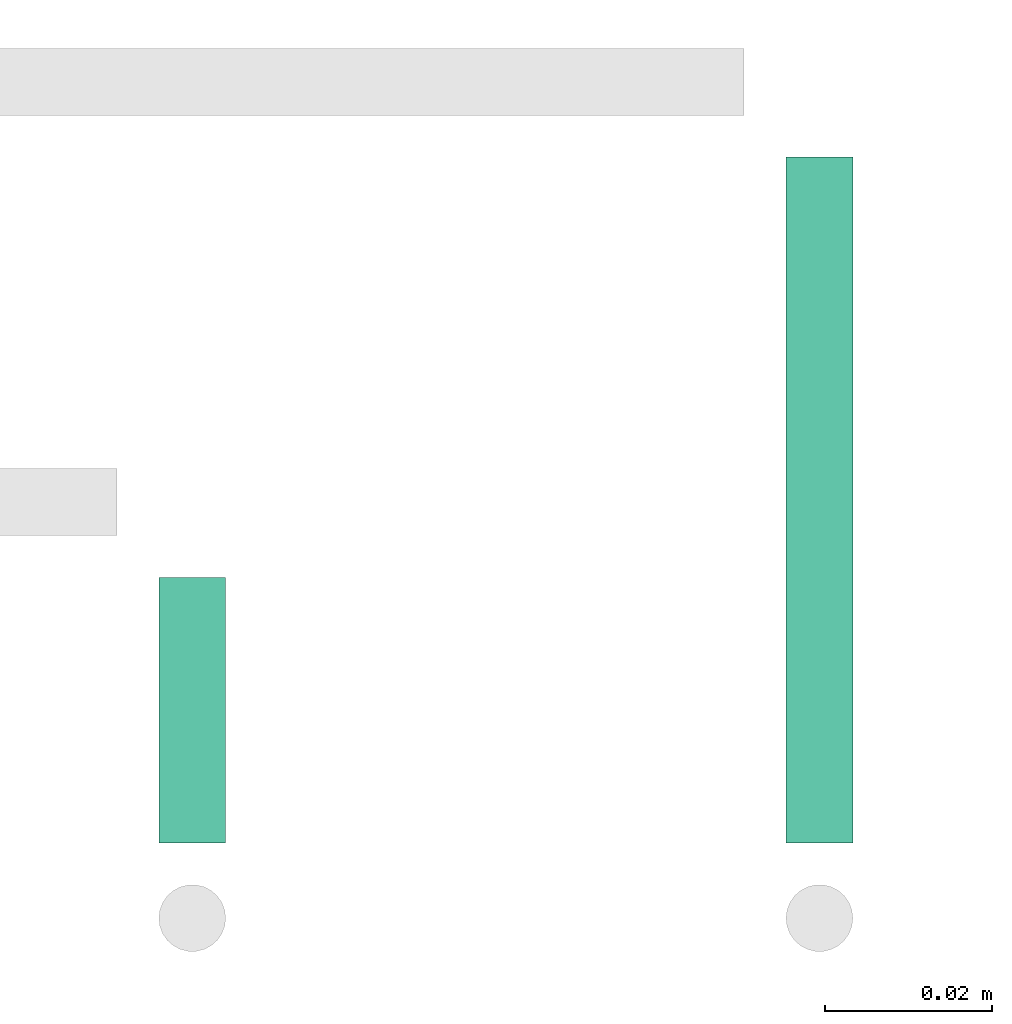
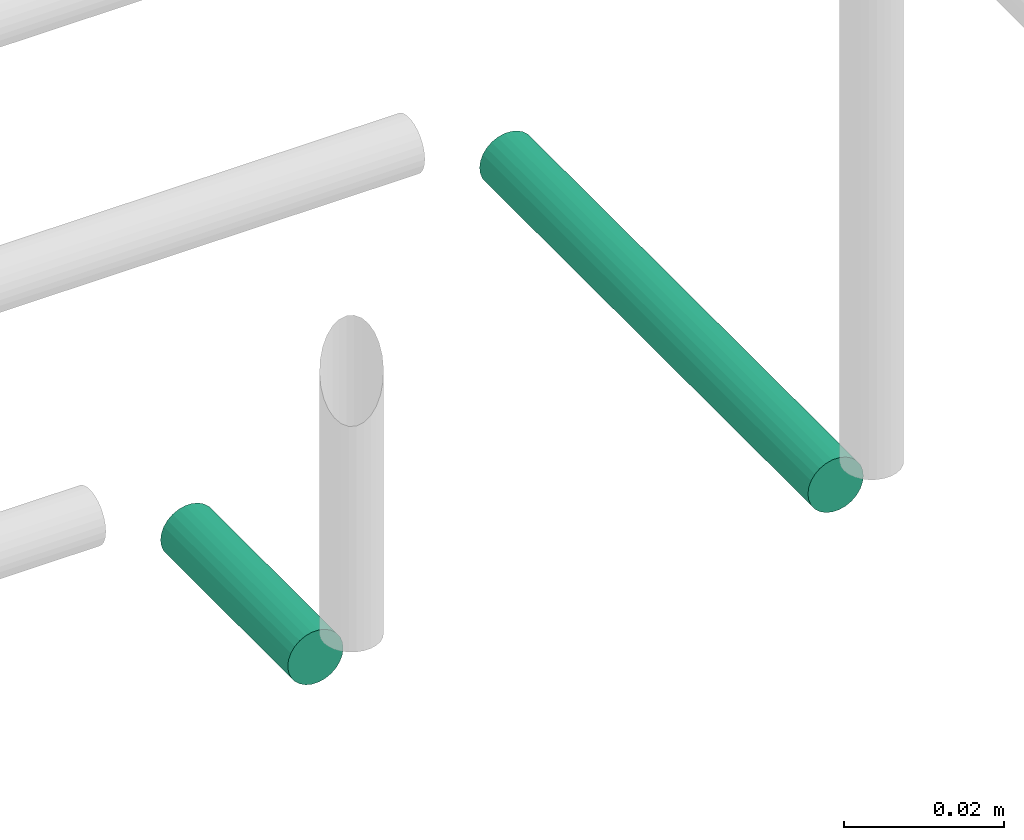
# One storey, part 306 of 331: 2 flow segments.
"""IFC2X3 building model written with IfcOpenShell, lengths in millimetres."""

from ifc_helpers import new_model, entity, si_unit, converted_unit, derived_unit, direction, frame, origin, origin_2d_with_axis, place, context, subcontext, project, spatial, circle, extrude, type_object, element, save


model = new_model("IFC2X3")

# Units and contexts
model_context = context("Model", 3, precision=0.01, world=origin(), true_north=direction((6.12303176911189e-17, 1.0)))
body_context = subcontext(model_context, "Body", "Model", "MODEL_VIEW")
ifc_project = project(units=[si_unit("LENGTHUNIT", "METRE", prefix="MILLI"), si_unit("AREAUNIT", "SQUARE_METRE"), si_unit("VOLUMEUNIT", "CUBIC_METRE"), converted_unit("PLANEANGLEUNIT", "DEGREE", entity("IfcRatioMeasure", 0.0174532925199433), si_unit("PLANEANGLEUNIT", "RADIAN"), dimensions=[0, 0, 0, 0, 0, 0, 0]), si_unit("MASSUNIT", "GRAM", prefix="KILO"), derived_unit("MASSDENSITYUNIT", [(si_unit("MASSUNIT", "GRAM", prefix="KILO"), 1), (si_unit("LENGTHUNIT", "METRE"), -3)]), derived_unit("MOMENTOFINERTIAUNIT", [(si_unit("LENGTHUNIT", "METRE"), 4)]), si_unit("TIMEUNIT", "SECOND"), si_unit("FREQUENCYUNIT", "HERTZ"), si_unit("THERMODYNAMICTEMPERATUREUNIT", "DEGREE_CELSIUS"), derived_unit("THERMALTRANSMITTANCEUNIT", [(si_unit("MASSUNIT", "GRAM", prefix="KILO"), 1), (si_unit("THERMODYNAMICTEMPERATUREUNIT", "KELVIN"), -1), (si_unit("TIMEUNIT", "SECOND"), -3)]), derived_unit("VOLUMETRICFLOWRATEUNIT", [(si_unit("LENGTHUNIT", "METRE"), 3), (si_unit("TIMEUNIT", "SECOND"), -1)]), derived_unit("MASSFLOWRATEUNIT", [(si_unit("MASSUNIT", "GRAM", prefix="KILO"), 1), (si_unit("TIMEUNIT", "SECOND"), -1)]), derived_unit("ROTATIONALFREQUENCYUNIT", [(si_unit("TIMEUNIT", "SECOND"), -1)]), si_unit("ELECTRICCURRENTUNIT", "AMPERE"), si_unit("ELECTRICVOLTAGEUNIT", "VOLT"), si_unit("POWERUNIT", "WATT"), si_unit("FORCEUNIT", "NEWTON", prefix="KILO"), si_unit("ILLUMINANCEUNIT", "LUX"), si_unit("LUMINOUSFLUXUNIT", "LUMEN"), si_unit("LUMINOUSINTENSITYUNIT", "CANDELA"), derived_unit("USERDEFINED", [(si_unit("MASSUNIT", "GRAM", prefix="KILO"), -1), (si_unit("LENGTHUNIT", "METRE"), -2), (si_unit("TIMEUNIT", "SECOND"), 3), (si_unit("LUMINOUSFLUXUNIT", "LUMEN"), 1)]), derived_unit("LINEARVELOCITYUNIT", [(si_unit("LENGTHUNIT", "METRE"), 1), (si_unit("TIMEUNIT", "SECOND"), -1)]), si_unit("PRESSUREUNIT", "PASCAL"), derived_unit("USERDEFINED", [(si_unit("LENGTHUNIT", "METRE"), -2), (si_unit("MASSUNIT", "GRAM", prefix="KILO"), 1), (si_unit("TIMEUNIT", "SECOND"), -2)]), derived_unit("LINEARFORCEUNIT", [(si_unit("MASSUNIT", "GRAM", prefix="KILO"), 1), (si_unit("LENGTHUNIT", "METRE"), 1), (si_unit("TIMEUNIT", "SECOND"), -2), (si_unit("LENGTHUNIT", "METRE"), -1)]), derived_unit("PLANARFORCEUNIT", [(si_unit("MASSUNIT", "GRAM", prefix="KILO"), 1), (si_unit("LENGTHUNIT", "METRE"), 1), (si_unit("TIMEUNIT", "SECOND"), -2), (si_unit("LENGTHUNIT", "METRE"), -2)])], contexts=[model_context])

# Site, building, storey
site_placement = place(None, frame((0.0, -0.00077364408347762, 0.0)))
site = spatial("IfcSite", under=ifc_project, at=site_placement, CompositionType="ELEMENT")
building_placement = place(site_placement, origin())
building = spatial("IfcBuilding", under=site, at=building_placement, CompositionType="ELEMENT")
storey_placement = place(building_placement, origin())
storey = spatial("IfcBuildingStorey", under=building, at=storey_placement, CompositionType="ELEMENT", Elevation=0.0)

# Flow segments
pipe_segment_type = type_object("IfcPipeSegmentType", PredefinedType="NOTDEFINED")
flow_segment_1_placement = place(storey_placement, frame((64894.5166110417, 7674.14924977608, 18444.4047277641)))
element("IfcFlowSegment", 1, at=flow_segment_1_placement, inside=storey, type_object=pipe_segment_type, context=body_context, shape_type="SweptSolid", body=[
    extrude(circle(Radius=4.0, at=origin_2d_with_axis()), frame((5.59527223591499, 0.0, 5.59527223591499), z_axis=(0.0, 1.0, 0.0), x_axis=(-1.0, 0.0, 0.0)), (0.0, 0.0, 1.0), 82.000000000003),
])
flow_segment_2_placement = place(storey_placement, frame((64819.5166110417, 7674.14924977607, 18444.4047277641)))
element("IfcFlowSegment", 2, at=flow_segment_2_placement, inside=storey, type_object=pipe_segment_type, context=body_context, shape_type="SweptSolid", body=[
    extrude(circle(Radius=4.0, at=origin_2d_with_axis()), frame((5.59527223591499, 0.0, 5.59527223591499), z_axis=(0.0, 1.0, 0.0), x_axis=(-1.0, 0.0, 0.0)), (0.0, 0.0, 1.0), 31.7600951017021),
])

save(model, "model.ifc")
